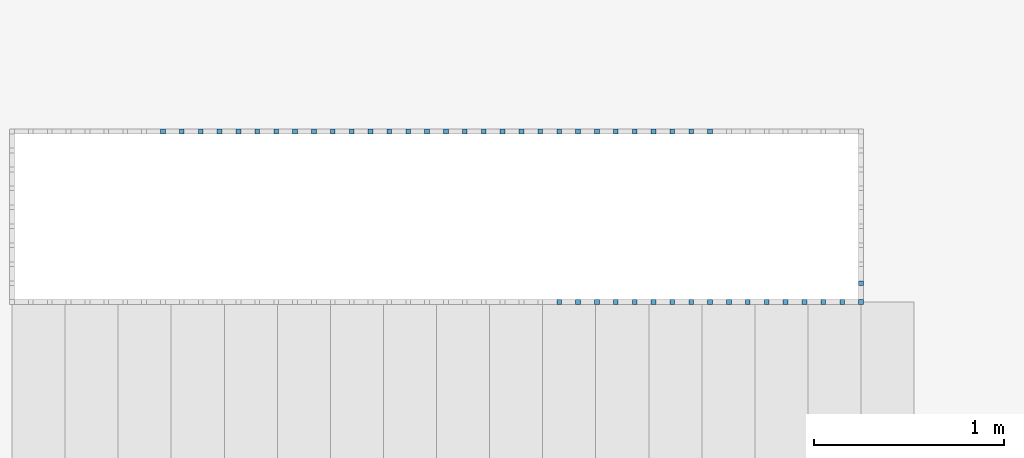
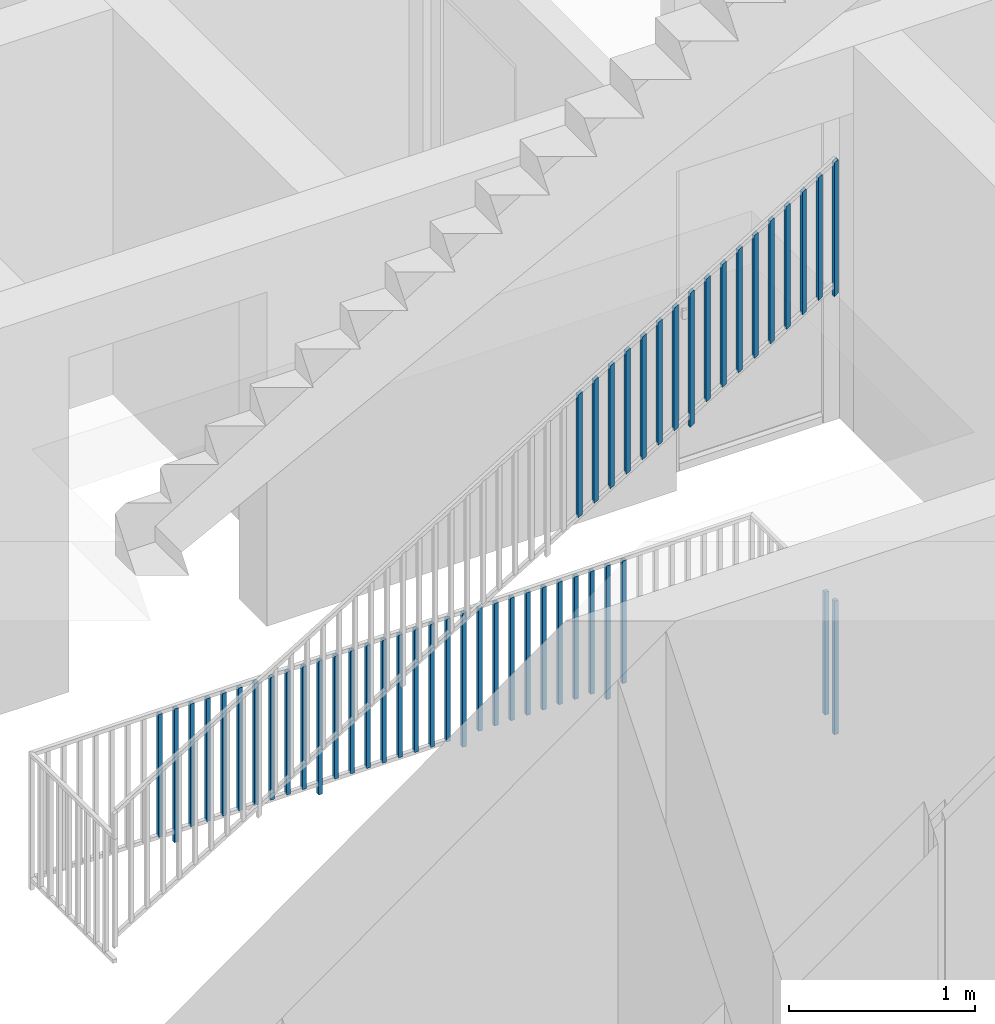
# One storey, part 34 of 48: 49 building element parts, 2 elements without a shape of their own.
"""IFC4 building model written with IfcOpenShell, lengths in metres."""

from ifc_helpers import new_model, entity, si_unit, converted_unit, derived_unit, direction, frame, origin_with_axes, place, context, subcontext, project, spatial, polygons, material, type_object, element, aggregate, save


model = new_model("IFC4")

# Units and contexts
model_context = context("Model", 3, precision=1e-05, world=origin_with_axes(), true_north=direction((0.0, 1.0)))
body_context = subcontext(model_context, "Body", "Model", "MODEL_VIEW")
ifc_project = project(units=[si_unit("LENGTHUNIT", "METRE"), si_unit("AREAUNIT", "SQUARE_METRE"), si_unit("VOLUMEUNIT", "CUBIC_METRE"), converted_unit("PLANEANGLEUNIT", "DEGREE", entity("IfcPlaneAngleMeasure", 0.0174532925199), si_unit("PLANEANGLEUNIT", "RADIAN"), dimensions=[0, 0, 0, 0, 0, 0, 0]), converted_unit("TIMEUNIT", "Year", entity("IfcTimeMeasure", 31556926.0), si_unit("TIMEUNIT", "SECOND"), dimensions=[0, 0, 1, 0, 0, 0, 0]), si_unit("MASSUNIT", "GRAM", prefix="KILO"), si_unit("THERMODYNAMICTEMPERATUREUNIT", "DEGREE_CELSIUS"), si_unit("LUMINOUSINTENSITYUNIT", "LUMEN"), si_unit("ENERGYUNIT", "JOULE", prefix="MEGA"), derived_unit("THERMALCONDUCTANCEUNIT", [(si_unit("POWERUNIT", "WATT"), 1), (si_unit("LENGTHUNIT", "METRE"), -1), (si_unit("THERMODYNAMICTEMPERATUREUNIT", "KELVIN"), -1)]), derived_unit("SPECIFICHEATCAPACITYUNIT", [(si_unit("ENERGYUNIT", "JOULE"), 1), (si_unit("MASSUNIT", "GRAM", prefix="KILO"), -1), (si_unit("THERMODYNAMICTEMPERATUREUNIT", "KELVIN"), -1)]), derived_unit("MASSDENSITYUNIT", [(si_unit("MASSUNIT", "GRAM", prefix="KILO"), 1), (si_unit("VOLUMEUNIT", "CUBIC_METRE"), -1)])], contexts=[model_context])

# Site, building, storey, space
site_placement = place(None, origin_with_axes())
site = spatial("IfcSite", under=ifc_project, at=site_placement, CompositionType="ELEMENT")
building_placement = place(site_placement, origin_with_axes())
building = spatial("IfcBuilding", under=site, at=building_placement, CompositionType="ELEMENT")
storey_placement = place(building_placement, frame((0.0, 0.0, 3.4), z_axis=(0.0, 0.0, 1.0), x_axis=(1.0, 0.0, 0.0)))
storey = spatial("IfcBuildingStorey", under=building, at=storey_placement, Name="1. Geschoss", CompositionType="ELEMENT", Elevation=3.4)
space_placement = place(storey_placement, frame((-3.4421993804, -2.52881223104, 0.0), z_axis=(0.0, 0.0, 1.0), x_axis=(1.0, 0.0, 0.0)))
space = spatial("IfcSpace", under=storey, at=space_placement, CompositionType="ELEMENT", PredefinedType="INTERNAL")

# Railing, building element parts
railing_type = type_object("IfcRailingType", PredefinedType="NOTDEFINED")
railing_1_placement = place(space_placement, frame((0.0, 1.5, 0.17), z_axis=(0.0, 0.0, 1.0), x_axis=(1.0, 0.0, 0.0)))
railing_1 = element("IfcRailing", 1, at=railing_1_placement, inside=space, type_object=railing_type, PredefinedType="NOTDEFINED")
ifc_material = material()
building_element_part_1_placement = place(railing_1_placement, origin_with_axes())
building_element_part_1 = element("IfcBuildingElementPart", 2, at=building_element_part_1_placement, material=ifc_material, PredefinedType="NOTDEFINED", context=body_context, shape_type="Tessellation", body=[
    polygons([(4.4925, -0.0125, 2.72758928571), (4.4925, 0.0125, 2.72758928571), (4.4925, 0.0125, 3.60758928571), (4.4925, -0.0125, 3.60758928571), (4.4675, -0.0125, 2.71241071429), (4.4675, 0.0125, 2.71241071429), (4.4675, 0.0125, 3.59241071429), (4.4675, -0.0125, 3.59241071429)], [[[1, 2, 3, 4]], [[1, 5, 6, 2]], [[2, 6, 7, 3]], [[4, 3, 7, 8]], [[5, 1, 4, 8]], [[6, 5, 8, 7]]], closed=True),
])
building_element_part_2_placement = place(railing_1_placement, origin_with_axes())
building_element_part_2 = element("IfcBuildingElementPart", 3, at=building_element_part_2_placement, material=ifc_material, PredefinedType="NOTDEFINED", context=body_context, shape_type="Tessellation", body=[
    polygons([(2.89961111111, -0.0125, 1.8304781746), (2.89961111111, 0.0125, 1.8304781746), (2.89961111111, 0.0125, 2.6379781746), (2.89961111111, -0.0125, 2.6379781746), (2.87461111111, -0.0125, 1.81529960317), (2.87461111111, 0.0125, 1.81529960317), (2.87461111111, 0.0125, 2.62279960317), (2.87461111111, -0.0125, 2.62279960317)], [[[1, 2, 3, 4]], [[1, 5, 6, 2]], [[2, 6, 7, 3]], [[4, 3, 7, 8]], [[5, 1, 4, 8]], [[6, 5, 8, 7]]], closed=True),
])
building_element_part_3_placement = place(railing_1_placement, origin_with_axes())
building_element_part_3 = element("IfcBuildingElementPart", 4, at=building_element_part_3_placement, material=ifc_material, PredefinedType="NOTDEFINED", context=body_context, shape_type="Tessellation", body=[
    polygons([(2.99916666667, -0.0125, 1.89092261905), (2.99916666667, 0.0125, 1.89092261905), (2.99916666667, 0.0125, 2.69842261905), (2.99916666667, -0.0125, 2.69842261905), (2.97416666667, -0.0125, 1.87574404762), (2.97416666667, 0.0125, 1.87574404762), (2.97416666667, 0.0125, 2.68324404762), (2.97416666667, -0.0125, 2.68324404762)], [[[1, 2, 3, 4]], [[1, 5, 6, 2]], [[2, 6, 7, 3]], [[4, 3, 7, 8]], [[5, 1, 4, 8]], [[6, 5, 8, 7]]], closed=True),
])
building_element_part_4_placement = place(railing_1_placement, origin_with_axes())
building_element_part_4 = element("IfcBuildingElementPart", 5, at=building_element_part_4_placement, material=ifc_material, PredefinedType="NOTDEFINED", context=body_context, shape_type="Tessellation", body=[
    polygons([(3.09872222222, -0.0125, 1.95136706349), (3.09872222222, 0.0125, 1.95136706349), (3.09872222222, 0.0125, 2.75886706349), (3.09872222222, -0.0125, 2.75886706349), (3.07372222222, -0.0125, 1.93618849206), (3.07372222222, 0.0125, 1.93618849206), (3.07372222222, 0.0125, 2.74368849206), (3.07372222222, -0.0125, 2.74368849206)], [[[1, 2, 3, 4]], [[1, 5, 6, 2]], [[2, 6, 7, 3]], [[4, 3, 7, 8]], [[5, 1, 4, 8]], [[6, 5, 8, 7]]], closed=True),
])
building_element_part_5_placement = place(railing_1_placement, origin_with_axes())
building_element_part_5 = element("IfcBuildingElementPart", 6, at=building_element_part_5_placement, material=ifc_material, PredefinedType="NOTDEFINED", context=body_context, shape_type="Tessellation", body=[
    polygons([(3.19827777778, -0.0125, 2.01181150794), (3.19827777778, 0.0125, 2.01181150794), (3.19827777778, 0.0125, 2.81931150794), (3.19827777778, -0.0125, 2.81931150794), (3.17327777778, -0.0125, 1.99663293651), (3.17327777778, 0.0125, 1.99663293651), (3.17327777778, 0.0125, 2.80413293651), (3.17327777778, -0.0125, 2.80413293651)], [[[1, 2, 3, 4]], [[1, 5, 6, 2]], [[2, 6, 7, 3]], [[4, 3, 7, 8]], [[5, 1, 4, 8]], [[6, 5, 8, 7]]], closed=True),
])
building_element_part_6_placement = place(railing_1_placement, origin_with_axes())
building_element_part_6 = element("IfcBuildingElementPart", 7, at=building_element_part_6_placement, material=ifc_material, PredefinedType="NOTDEFINED", context=body_context, shape_type="Tessellation", body=[
    polygons([(3.29783333333, -0.0125, 2.07225595238), (3.29783333333, 0.0125, 2.07225595238), (3.29783333333, 0.0125, 2.87975595238), (3.29783333333, -0.0125, 2.87975595238), (3.27283333333, -0.0125, 2.05707738095), (3.27283333333, 0.0125, 2.05707738095), (3.27283333333, 0.0125, 2.86457738095), (3.27283333333, -0.0125, 2.86457738095)], [[[1, 2, 3, 4]], [[1, 5, 6, 2]], [[2, 6, 7, 3]], [[4, 3, 7, 8]], [[5, 1, 4, 8]], [[6, 5, 8, 7]]], closed=True),
])
building_element_part_7_placement = place(railing_1_placement, origin_with_axes())
building_element_part_7 = element("IfcBuildingElementPart", 8, at=building_element_part_7_placement, material=ifc_material, PredefinedType="NOTDEFINED", context=body_context, shape_type="Tessellation", body=[
    polygons([(3.39738888889, -0.0125, 2.13270039683), (3.39738888889, 0.0125, 2.13270039683), (3.39738888889, 0.0125, 2.94020039683), (3.39738888889, -0.0125, 2.94020039683), (3.37238888889, -0.0125, 2.1175218254), (3.37238888889, 0.0125, 2.1175218254), (3.37238888889, 0.0125, 2.9250218254), (3.37238888889, -0.0125, 2.9250218254)], [[[1, 2, 3, 4]], [[1, 5, 6, 2]], [[2, 6, 7, 3]], [[4, 3, 7, 8]], [[5, 1, 4, 8]], [[6, 5, 8, 7]]], closed=True),
])
building_element_part_8_placement = place(railing_1_placement, origin_with_axes())
building_element_part_8 = element("IfcBuildingElementPart", 9, at=building_element_part_8_placement, material=ifc_material, PredefinedType="NOTDEFINED", context=body_context, shape_type="Tessellation", body=[
    polygons([(3.49694444444, -0.0125, 2.19314484127), (3.49694444444, 0.0125, 2.19314484127), (3.49694444444, 0.0125, 3.00064484127), (3.49694444444, -0.0125, 3.00064484127), (3.47194444444, -0.0125, 2.17796626984), (3.47194444444, 0.0125, 2.17796626984), (3.47194444444, 0.0125, 2.98546626984), (3.47194444444, -0.0125, 2.98546626984)], [[[1, 2, 3, 4]], [[1, 5, 6, 2]], [[2, 6, 7, 3]], [[4, 3, 7, 8]], [[5, 1, 4, 8]], [[6, 5, 8, 7]]], closed=True),
])
building_element_part_9_placement = place(railing_1_placement, origin_with_axes())
building_element_part_9 = element("IfcBuildingElementPart", 10, at=building_element_part_9_placement, material=ifc_material, PredefinedType="NOTDEFINED", context=body_context, shape_type="Tessellation", body=[
    polygons([(3.5965, -0.0125, 2.18358928571), (3.5965, 0.0125, 2.18358928571), (3.5965, 0.0125, 3.06358928571), (3.5965, -0.0125, 3.06358928571), (3.5715, -0.0125, 2.16841071429), (3.5715, 0.0125, 2.16841071429), (3.5715, 0.0125, 3.04841071429), (3.5715, -0.0125, 3.04841071429)], [[[1, 2, 3, 4]], [[1, 5, 6, 2]], [[2, 6, 7, 3]], [[4, 3, 7, 8]], [[5, 1, 4, 8]], [[6, 5, 8, 7]]], closed=True),
])
building_element_part_10_placement = place(railing_1_placement, origin_with_axes())
building_element_part_10 = element("IfcBuildingElementPart", 11, at=building_element_part_10_placement, material=ifc_material, PredefinedType="NOTDEFINED", context=body_context, shape_type="Tessellation", body=[
    polygons([(3.69605555556, -0.0125, 2.31403373016), (3.69605555556, 0.0125, 2.31403373016), (3.69605555556, 0.0125, 3.12153373016), (3.69605555556, -0.0125, 3.12153373016), (3.67105555556, -0.0125, 2.29885515873), (3.67105555556, 0.0125, 2.29885515873), (3.67105555556, 0.0125, 3.10635515873), (3.67105555556, -0.0125, 3.10635515873)], [[[1, 2, 3, 4]], [[1, 5, 6, 2]], [[2, 6, 7, 3]], [[4, 3, 7, 8]], [[5, 1, 4, 8]], [[6, 5, 8, 7]]], closed=True),
])
building_element_part_11_placement = place(railing_1_placement, origin_with_axes())
building_element_part_11 = element("IfcBuildingElementPart", 12, at=building_element_part_11_placement, material=ifc_material, PredefinedType="NOTDEFINED", context=body_context, shape_type="Tessellation", body=[
    polygons([(3.79561111111, -0.0125, 2.3744781746), (3.79561111111, 0.0125, 2.3744781746), (3.79561111111, 0.0125, 3.1819781746), (3.79561111111, -0.0125, 3.1819781746), (3.77061111111, -0.0125, 2.35929960317), (3.77061111111, 0.0125, 2.35929960317), (3.77061111111, 0.0125, 3.16679960317), (3.77061111111, -0.0125, 3.16679960317)], [[[1, 2, 3, 4]], [[1, 5, 6, 2]], [[2, 6, 7, 3]], [[4, 3, 7, 8]], [[5, 1, 4, 8]], [[6, 5, 8, 7]]], closed=True),
])
building_element_part_12_placement = place(railing_1_placement, origin_with_axes())
building_element_part_12 = element("IfcBuildingElementPart", 13, at=building_element_part_12_placement, material=ifc_material, PredefinedType="NOTDEFINED", context=body_context, shape_type="Tessellation", body=[
    polygons([(3.89516666667, -0.0125, 2.43492261905), (3.89516666667, 0.0125, 2.43492261905), (3.89516666667, 0.0125, 3.24242261905), (3.89516666667, -0.0125, 3.24242261905), (3.87016666667, -0.0125, 2.41974404762), (3.87016666667, 0.0125, 2.41974404762), (3.87016666667, 0.0125, 3.22724404762), (3.87016666667, -0.0125, 3.22724404762)], [[[1, 2, 3, 4]], [[1, 5, 6, 2]], [[2, 6, 7, 3]], [[4, 3, 7, 8]], [[5, 1, 4, 8]], [[6, 5, 8, 7]]], closed=True),
])
building_element_part_13_placement = place(railing_1_placement, origin_with_axes())
building_element_part_13 = element("IfcBuildingElementPart", 14, at=building_element_part_13_placement, material=ifc_material, PredefinedType="NOTDEFINED", context=body_context, shape_type="Tessellation", body=[
    polygons([(3.99472222222, -0.0125, 2.49536706349), (3.99472222222, 0.0125, 2.49536706349), (3.99472222222, 0.0125, 3.30286706349), (3.99472222222, -0.0125, 3.30286706349), (3.96972222222, -0.0125, 2.48018849206), (3.96972222222, 0.0125, 2.48018849206), (3.96972222222, 0.0125, 3.28768849206), (3.96972222222, -0.0125, 3.28768849206)], [[[1, 2, 3, 4]], [[1, 5, 6, 2]], [[2, 6, 7, 3]], [[4, 3, 7, 8]], [[5, 1, 4, 8]], [[6, 5, 8, 7]]], closed=True),
])
building_element_part_14_placement = place(railing_1_placement, origin_with_axes())
building_element_part_14 = element("IfcBuildingElementPart", 15, at=building_element_part_14_placement, material=ifc_material, PredefinedType="NOTDEFINED", context=body_context, shape_type="Tessellation", body=[
    polygons([(4.09427777778, -0.0125, 2.55581150794), (4.09427777778, 0.0125, 2.55581150794), (4.09427777778, 0.0125, 3.36331150794), (4.09427777778, -0.0125, 3.36331150794), (4.06927777778, -0.0125, 2.54063293651), (4.06927777778, 0.0125, 2.54063293651), (4.06927777778, 0.0125, 3.34813293651), (4.06927777778, -0.0125, 3.34813293651)], [[[1, 2, 3, 4]], [[1, 5, 6, 2]], [[2, 6, 7, 3]], [[4, 3, 7, 8]], [[5, 1, 4, 8]], [[6, 5, 8, 7]]], closed=True),
])
building_element_part_15_placement = place(railing_1_placement, origin_with_axes())
building_element_part_15 = element("IfcBuildingElementPart", 16, at=building_element_part_15_placement, material=ifc_material, PredefinedType="NOTDEFINED", context=body_context, shape_type="Tessellation", body=[
    polygons([(4.19383333333, -0.0125, 2.61625595238), (4.19383333333, 0.0125, 2.61625595238), (4.19383333333, 0.0125, 3.42375595238), (4.19383333333, -0.0125, 3.42375595238), (4.16883333333, -0.0125, 2.60107738095), (4.16883333333, 0.0125, 2.60107738095), (4.16883333333, 0.0125, 3.40857738095), (4.16883333333, -0.0125, 3.40857738095)], [[[1, 2, 3, 4]], [[1, 5, 6, 2]], [[2, 6, 7, 3]], [[4, 3, 7, 8]], [[5, 1, 4, 8]], [[6, 5, 8, 7]]], closed=True),
])
building_element_part_16_placement = place(railing_1_placement, origin_with_axes())
building_element_part_16 = element("IfcBuildingElementPart", 17, at=building_element_part_16_placement, material=ifc_material, PredefinedType="NOTDEFINED", context=body_context, shape_type="Tessellation", body=[
    polygons([(4.29338888889, -0.0125, 2.67670039683), (4.29338888889, 0.0125, 2.67670039683), (4.29338888889, 0.0125, 3.48420039683), (4.29338888889, -0.0125, 3.48420039683), (4.26838888889, -0.0125, 2.6615218254), (4.26838888889, 0.0125, 2.6615218254), (4.26838888889, 0.0125, 3.4690218254), (4.26838888889, -0.0125, 3.4690218254)], [[[1, 2, 3, 4]], [[1, 5, 6, 2]], [[2, 6, 7, 3]], [[4, 3, 7, 8]], [[5, 1, 4, 8]], [[6, 5, 8, 7]]], closed=True),
])
building_element_part_17_placement = place(railing_1_placement, origin_with_axes())
building_element_part_17 = element("IfcBuildingElementPart", 18, at=building_element_part_17_placement, material=ifc_material, PredefinedType="NOTDEFINED", context=body_context, shape_type="Tessellation", body=[
    polygons([(4.39294444444, -0.0125, 2.73714484127), (4.39294444444, 0.0125, 2.73714484127), (4.39294444444, 0.0125, 3.54464484127), (4.39294444444, -0.0125, 3.54464484127), (4.36794444444, -0.0125, 2.72196626984), (4.36794444444, 0.0125, 2.72196626984), (4.36794444444, 0.0125, 3.52946626984), (4.36794444444, -0.0125, 3.52946626984)], [[[1, 2, 3, 4]], [[1, 5, 6, 2]], [[2, 6, 7, 3]], [[4, 3, 7, 8]], [[5, 1, 4, 8]], [[6, 5, 8, 7]]], closed=True),
])
aggregate(railing_1, [building_element_part_1, building_element_part_2, building_element_part_3, building_element_part_4, building_element_part_5, building_element_part_6, building_element_part_7, building_element_part_8, building_element_part_9, building_element_part_10, building_element_part_11, building_element_part_12, building_element_part_13, building_element_part_14, building_element_part_15, building_element_part_16, building_element_part_17])

railing_2_placement = place(space_placement, frame((0.0, 1.5, 0.0), z_axis=(0.0, 0.0, 1.0), x_axis=(1.0, 0.0, 0.0)))
railing_2 = element("IfcRailing", 19, at=railing_2_placement, inside=space, type_object=railing_type, PredefinedType="NOTDEFINED")
building_element_part_18_placement = place(railing_2_placement, origin_with_axes())
building_element_part_18 = element("IfcBuildingElementPart", 20, at=building_element_part_18_placement, material=ifc_material, PredefinedType="NOTDEFINED", context=body_context, shape_type="Tessellation", body=[
    polygons([(4.4675, -0.0125, 0.0), (4.4925, -0.0125, 0.0), (4.4925, -0.0125, 0.88), (4.4675, -0.0125, 0.88), (4.4675, 0.0125, 0.0), (4.4925, 0.0125, 0.0), (4.4925, 0.0125, 0.88), (4.4675, 0.0125, 0.88)], [[[1, 2, 3, 4]], [[1, 5, 6, 2]], [[2, 6, 7, 3]], [[4, 3, 7, 8]], [[5, 1, 4, 8]], [[6, 5, 8, 7]]], closed=True),
])
building_element_part_19_placement = place(railing_2_placement, origin_with_axes())
building_element_part_19 = element("IfcBuildingElementPart", 21, at=building_element_part_19_placement, material=ifc_material, PredefinedType="NOTDEFINED", context=body_context, shape_type="Tessellation", body=[
    polygons([(0.808944444444, 0.8875, 0.07), (0.808944444444, 0.9125, 0.07), (0.808944444444, 0.9125, 0.8775), (0.808944444444, 0.8875, 0.8775), (0.783944444444, 0.8875, 0.07), (0.783944444444, 0.9125, 0.07), (0.783944444444, 0.9125, 0.8775), (0.783944444444, 0.8875, 0.8775)], [[[1, 2, 3, 4]], [[1, 5, 6, 2]], [[2, 6, 7, 3]], [[4, 3, 7, 8]], [[5, 1, 4, 8]], [[6, 5, 8, 7]]], closed=True),
])
building_element_part_20_placement = place(railing_2_placement, origin_with_axes())
building_element_part_20 = element("IfcBuildingElementPart", 22, at=building_element_part_20_placement, material=ifc_material, PredefinedType="NOTDEFINED", context=body_context, shape_type="Tessellation", body=[
    polygons([(0.9085, 0.8875, 0.0), (0.9085, 0.9125, 0.0), (0.9085, 0.9125, 0.88), (0.9085, 0.8875, 0.88), (0.8835, 0.8875, 0.0), (0.8835, 0.9125, 0.0), (0.8835, 0.9125, 0.88), (0.8835, 0.8875, 0.88)], [[[1, 2, 3, 4]], [[1, 5, 6, 2]], [[2, 6, 7, 3]], [[4, 3, 7, 8]], [[5, 1, 4, 8]], [[6, 5, 8, 7]]], closed=True),
])
building_element_part_21_placement = place(railing_2_placement, origin_with_axes())
building_element_part_21 = element("IfcBuildingElementPart", 23, at=building_element_part_21_placement, material=ifc_material, PredefinedType="NOTDEFINED", context=body_context, shape_type="Tessellation", body=[
    polygons([(1.00805555556, 0.8875, 0.07), (1.00805555556, 0.9125, 0.07), (1.00805555556, 0.9125, 0.8775), (1.00805555556, 0.8875, 0.8775), (0.983055555556, 0.8875, 0.07), (0.983055555556, 0.9125, 0.07), (0.983055555556, 0.9125, 0.8775), (0.983055555556, 0.8875, 0.8775)], [[[1, 2, 3, 4]], [[1, 5, 6, 2]], [[2, 6, 7, 3]], [[4, 3, 7, 8]], [[5, 1, 4, 8]], [[6, 5, 8, 7]]], closed=True),
])
building_element_part_22_placement = place(railing_2_placement, origin_with_axes())
building_element_part_22 = element("IfcBuildingElementPart", 24, at=building_element_part_22_placement, material=ifc_material, PredefinedType="NOTDEFINED", context=body_context, shape_type="Tessellation", body=[
    polygons([(1.10761111111, 0.8875, 0.07), (1.10761111111, 0.9125, 0.07), (1.10761111111, 0.9125, 0.8775), (1.10761111111, 0.8875, 0.8775), (1.08261111111, 0.8875, 0.07), (1.08261111111, 0.9125, 0.07), (1.08261111111, 0.9125, 0.8775), (1.08261111111, 0.8875, 0.8775)], [[[1, 2, 3, 4]], [[1, 5, 6, 2]], [[2, 6, 7, 3]], [[4, 3, 7, 8]], [[5, 1, 4, 8]], [[6, 5, 8, 7]]], closed=True),
])
building_element_part_23_placement = place(railing_2_placement, origin_with_axes())
building_element_part_23 = element("IfcBuildingElementPart", 25, at=building_element_part_23_placement, material=ifc_material, PredefinedType="NOTDEFINED", context=body_context, shape_type="Tessellation", body=[
    polygons([(1.20716666667, 0.8875, 0.07), (1.20716666667, 0.9125, 0.07), (1.20716666667, 0.9125, 0.8775), (1.20716666667, 0.8875, 0.8775), (1.18216666667, 0.8875, 0.07), (1.18216666667, 0.9125, 0.07), (1.18216666667, 0.9125, 0.8775), (1.18216666667, 0.8875, 0.8775)], [[[1, 2, 3, 4]], [[1, 5, 6, 2]], [[2, 6, 7, 3]], [[4, 3, 7, 8]], [[5, 1, 4, 8]], [[6, 5, 8, 7]]], closed=True),
])
building_element_part_24_placement = place(railing_2_placement, origin_with_axes())
building_element_part_24 = element("IfcBuildingElementPart", 26, at=building_element_part_24_placement, material=ifc_material, PredefinedType="NOTDEFINED", context=body_context, shape_type="Tessellation", body=[
    polygons([(1.30672222222, 0.8875, 0.07), (1.30672222222, 0.9125, 0.07), (1.30672222222, 0.9125, 0.8775), (1.30672222222, 0.8875, 0.8775), (1.28172222222, 0.8875, 0.07), (1.28172222222, 0.9125, 0.07), (1.28172222222, 0.9125, 0.8775), (1.28172222222, 0.8875, 0.8775)], [[[1, 2, 3, 4]], [[1, 5, 6, 2]], [[2, 6, 7, 3]], [[4, 3, 7, 8]], [[5, 1, 4, 8]], [[6, 5, 8, 7]]], closed=True),
])
building_element_part_25_placement = place(railing_2_placement, origin_with_axes())
building_element_part_25 = element("IfcBuildingElementPart", 27, at=building_element_part_25_placement, material=ifc_material, PredefinedType="NOTDEFINED", context=body_context, shape_type="Tessellation", body=[
    polygons([(1.40627777778, 0.8875, 0.07), (1.40627777778, 0.9125, 0.07), (1.40627777778, 0.9125, 0.8775), (1.40627777778, 0.8875, 0.8775), (1.38127777778, 0.8875, 0.07), (1.38127777778, 0.9125, 0.07), (1.38127777778, 0.9125, 0.8775), (1.38127777778, 0.8875, 0.8775)], [[[1, 2, 3, 4]], [[1, 5, 6, 2]], [[2, 6, 7, 3]], [[4, 3, 7, 8]], [[5, 1, 4, 8]], [[6, 5, 8, 7]]], closed=True),
])
building_element_part_26_placement = place(railing_2_placement, origin_with_axes())
building_element_part_26 = element("IfcBuildingElementPart", 28, at=building_element_part_26_placement, material=ifc_material, PredefinedType="NOTDEFINED", context=body_context, shape_type="Tessellation", body=[
    polygons([(1.50583333333, 0.8875, 0.07), (1.50583333333, 0.9125, 0.07), (1.50583333333, 0.9125, 0.8775), (1.50583333333, 0.8875, 0.8775), (1.48083333333, 0.8875, 0.07), (1.48083333333, 0.9125, 0.07), (1.48083333333, 0.9125, 0.8775), (1.48083333333, 0.8875, 0.8775)], [[[1, 2, 3, 4]], [[1, 5, 6, 2]], [[2, 6, 7, 3]], [[4, 3, 7, 8]], [[5, 1, 4, 8]], [[6, 5, 8, 7]]], closed=True),
])
building_element_part_27_placement = place(railing_2_placement, origin_with_axes())
building_element_part_27 = element("IfcBuildingElementPart", 29, at=building_element_part_27_placement, material=ifc_material, PredefinedType="NOTDEFINED", context=body_context, shape_type="Tessellation", body=[
    polygons([(1.60538888889, 0.8875, 0.07), (1.60538888889, 0.9125, 0.07), (1.60538888889, 0.9125, 0.8775), (1.60538888889, 0.8875, 0.8775), (1.58038888889, 0.8875, 0.07), (1.58038888889, 0.9125, 0.07), (1.58038888889, 0.9125, 0.8775), (1.58038888889, 0.8875, 0.8775)], [[[1, 2, 3, 4]], [[1, 5, 6, 2]], [[2, 6, 7, 3]], [[4, 3, 7, 8]], [[5, 1, 4, 8]], [[6, 5, 8, 7]]], closed=True),
])
building_element_part_28_placement = place(railing_2_placement, origin_with_axes())
building_element_part_28 = element("IfcBuildingElementPart", 30, at=building_element_part_28_placement, material=ifc_material, PredefinedType="NOTDEFINED", context=body_context, shape_type="Tessellation", body=[
    polygons([(1.70494444444, 0.8875, 0.07), (1.70494444444, 0.9125, 0.07), (1.70494444444, 0.9125, 0.8775), (1.70494444444, 0.8875, 0.8775), (1.67994444444, 0.8875, 0.07), (1.67994444444, 0.9125, 0.07), (1.67994444444, 0.9125, 0.8775), (1.67994444444, 0.8875, 0.8775)], [[[1, 2, 3, 4]], [[1, 5, 6, 2]], [[2, 6, 7, 3]], [[4, 3, 7, 8]], [[5, 1, 4, 8]], [[6, 5, 8, 7]]], closed=True),
])
building_element_part_29_placement = place(railing_2_placement, origin_with_axes())
building_element_part_29 = element("IfcBuildingElementPart", 31, at=building_element_part_29_placement, material=ifc_material, PredefinedType="NOTDEFINED", context=body_context, shape_type="Tessellation", body=[
    polygons([(1.8045, 0.8875, 0.0), (1.8045, 0.9125, 0.0), (1.8045, 0.9125, 0.88), (1.8045, 0.8875, 0.88), (1.7795, 0.8875, 0.0), (1.7795, 0.9125, 0.0), (1.7795, 0.9125, 0.88), (1.7795, 0.8875, 0.88)], [[[1, 2, 3, 4]], [[1, 5, 6, 2]], [[2, 6, 7, 3]], [[4, 3, 7, 8]], [[5, 1, 4, 8]], [[6, 5, 8, 7]]], closed=True),
])
building_element_part_30_placement = place(railing_2_placement, origin_with_axes())
building_element_part_30 = element("IfcBuildingElementPart", 32, at=building_element_part_30_placement, material=ifc_material, PredefinedType="NOTDEFINED", context=body_context, shape_type="Tessellation", body=[
    polygons([(1.90405555556, 0.8875, 0.07), (1.90405555556, 0.9125, 0.07), (1.90405555556, 0.9125, 0.8775), (1.90405555556, 0.8875, 0.8775), (1.87905555556, 0.8875, 0.07), (1.87905555556, 0.9125, 0.07), (1.87905555556, 0.9125, 0.8775), (1.87905555556, 0.8875, 0.8775)], [[[1, 2, 3, 4]], [[1, 5, 6, 2]], [[2, 6, 7, 3]], [[4, 3, 7, 8]], [[5, 1, 4, 8]], [[6, 5, 8, 7]]], closed=True),
])
building_element_part_31_placement = place(railing_2_placement, origin_with_axes())
building_element_part_31 = element("IfcBuildingElementPart", 33, at=building_element_part_31_placement, material=ifc_material, PredefinedType="NOTDEFINED", context=body_context, shape_type="Tessellation", body=[
    polygons([(2.00361111111, 0.8875, 0.07), (2.00361111111, 0.9125, 0.07), (2.00361111111, 0.9125, 0.8775), (2.00361111111, 0.8875, 0.8775), (1.97861111111, 0.8875, 0.07), (1.97861111111, 0.9125, 0.07), (1.97861111111, 0.9125, 0.8775), (1.97861111111, 0.8875, 0.8775)], [[[1, 2, 3, 4]], [[1, 5, 6, 2]], [[2, 6, 7, 3]], [[4, 3, 7, 8]], [[5, 1, 4, 8]], [[6, 5, 8, 7]]], closed=True),
])
building_element_part_32_placement = place(railing_2_placement, origin_with_axes())
building_element_part_32 = element("IfcBuildingElementPart", 34, at=building_element_part_32_placement, material=ifc_material, PredefinedType="NOTDEFINED", context=body_context, shape_type="Tessellation", body=[
    polygons([(2.10316666667, 0.8875, 0.07), (2.10316666667, 0.9125, 0.07), (2.10316666667, 0.9125, 0.8775), (2.10316666667, 0.8875, 0.8775), (2.07816666667, 0.8875, 0.07), (2.07816666667, 0.9125, 0.07), (2.07816666667, 0.9125, 0.8775), (2.07816666667, 0.8875, 0.8775)], [[[1, 2, 3, 4]], [[1, 5, 6, 2]], [[2, 6, 7, 3]], [[4, 3, 7, 8]], [[5, 1, 4, 8]], [[6, 5, 8, 7]]], closed=True),
])
building_element_part_33_placement = place(railing_2_placement, origin_with_axes())
building_element_part_33 = element("IfcBuildingElementPart", 35, at=building_element_part_33_placement, material=ifc_material, PredefinedType="NOTDEFINED", context=body_context, shape_type="Tessellation", body=[
    polygons([(2.20272222222, 0.8875, 0.07), (2.20272222222, 0.9125, 0.07), (2.20272222222, 0.9125, 0.8775), (2.20272222222, 0.8875, 0.8775), (2.17772222222, 0.8875, 0.07), (2.17772222222, 0.9125, 0.07), (2.17772222222, 0.9125, 0.8775), (2.17772222222, 0.8875, 0.8775)], [[[1, 2, 3, 4]], [[1, 5, 6, 2]], [[2, 6, 7, 3]], [[4, 3, 7, 8]], [[5, 1, 4, 8]], [[6, 5, 8, 7]]], closed=True),
])
building_element_part_34_placement = place(railing_2_placement, origin_with_axes())
building_element_part_34 = element("IfcBuildingElementPart", 36, at=building_element_part_34_placement, material=ifc_material, PredefinedType="NOTDEFINED", context=body_context, shape_type="Tessellation", body=[
    polygons([(2.30227777778, 0.8875, 0.07), (2.30227777778, 0.9125, 0.07), (2.30227777778, 0.9125, 0.8775), (2.30227777778, 0.8875, 0.8775), (2.27727777778, 0.8875, 0.07), (2.27727777778, 0.9125, 0.07), (2.27727777778, 0.9125, 0.8775), (2.27727777778, 0.8875, 0.8775)], [[[1, 2, 3, 4]], [[1, 5, 6, 2]], [[2, 6, 7, 3]], [[4, 3, 7, 8]], [[5, 1, 4, 8]], [[6, 5, 8, 7]]], closed=True),
])
building_element_part_35_placement = place(railing_2_placement, origin_with_axes())
building_element_part_35 = element("IfcBuildingElementPart", 37, at=building_element_part_35_placement, material=ifc_material, PredefinedType="NOTDEFINED", context=body_context, shape_type="Tessellation", body=[
    polygons([(2.40183333333, 0.8875, 0.07), (2.40183333333, 0.9125, 0.07), (2.40183333333, 0.9125, 0.8775), (2.40183333333, 0.8875, 0.8775), (2.37683333333, 0.8875, 0.07), (2.37683333333, 0.9125, 0.07), (2.37683333333, 0.9125, 0.8775), (2.37683333333, 0.8875, 0.8775)], [[[1, 2, 3, 4]], [[1, 5, 6, 2]], [[2, 6, 7, 3]], [[4, 3, 7, 8]], [[5, 1, 4, 8]], [[6, 5, 8, 7]]], closed=True),
])
building_element_part_36_placement = place(railing_2_placement, origin_with_axes())
building_element_part_36 = element("IfcBuildingElementPart", 38, at=building_element_part_36_placement, material=ifc_material, PredefinedType="NOTDEFINED", context=body_context, shape_type="Tessellation", body=[
    polygons([(2.50138888889, 0.8875, 0.07), (2.50138888889, 0.9125, 0.07), (2.50138888889, 0.9125, 0.8775), (2.50138888889, 0.8875, 0.8775), (2.47638888889, 0.8875, 0.07), (2.47638888889, 0.9125, 0.07), (2.47638888889, 0.9125, 0.8775), (2.47638888889, 0.8875, 0.8775)], [[[1, 2, 3, 4]], [[1, 5, 6, 2]], [[2, 6, 7, 3]], [[4, 3, 7, 8]], [[5, 1, 4, 8]], [[6, 5, 8, 7]]], closed=True),
])
building_element_part_37_placement = place(railing_2_placement, origin_with_axes())
building_element_part_37 = element("IfcBuildingElementPart", 39, at=building_element_part_37_placement, material=ifc_material, PredefinedType="NOTDEFINED", context=body_context, shape_type="Tessellation", body=[
    polygons([(2.60094444444, 0.8875, 0.07), (2.60094444444, 0.9125, 0.07), (2.60094444444, 0.9125, 0.8775), (2.60094444444, 0.8875, 0.8775), (2.57594444444, 0.8875, 0.07), (2.57594444444, 0.9125, 0.07), (2.57594444444, 0.9125, 0.8775), (2.57594444444, 0.8875, 0.8775)], [[[1, 2, 3, 4]], [[1, 5, 6, 2]], [[2, 6, 7, 3]], [[4, 3, 7, 8]], [[5, 1, 4, 8]], [[6, 5, 8, 7]]], closed=True),
])
building_element_part_38_placement = place(railing_2_placement, origin_with_axes())
building_element_part_38 = element("IfcBuildingElementPart", 40, at=building_element_part_38_placement, material=ifc_material, PredefinedType="NOTDEFINED", context=body_context, shape_type="Tessellation", body=[
    polygons([(2.7005, 0.8875, 0.0), (2.7005, 0.9125, 0.0), (2.7005, 0.9125, 0.88), (2.7005, 0.8875, 0.88), (2.6755, 0.8875, 0.0), (2.6755, 0.9125, 0.0), (2.6755, 0.9125, 0.88), (2.6755, 0.8875, 0.88)], [[[1, 2, 3, 4]], [[1, 5, 6, 2]], [[2, 6, 7, 3]], [[4, 3, 7, 8]], [[5, 1, 4, 8]], [[6, 5, 8, 7]]], closed=True),
])
building_element_part_39_placement = place(railing_2_placement, origin_with_axes())
building_element_part_39 = element("IfcBuildingElementPart", 41, at=building_element_part_39_placement, material=ifc_material, PredefinedType="NOTDEFINED", context=body_context, shape_type="Tessellation", body=[
    polygons([(2.80005555556, 0.8875, 0.07), (2.80005555556, 0.9125, 0.07), (2.80005555556, 0.9125, 0.8775), (2.80005555556, 0.8875, 0.8775), (2.77505555556, 0.8875, 0.07), (2.77505555556, 0.9125, 0.07), (2.77505555556, 0.9125, 0.8775), (2.77505555556, 0.8875, 0.8775)], [[[1, 2, 3, 4]], [[1, 5, 6, 2]], [[2, 6, 7, 3]], [[4, 3, 7, 8]], [[5, 1, 4, 8]], [[6, 5, 8, 7]]], closed=True),
])
building_element_part_40_placement = place(railing_2_placement, origin_with_axes())
building_element_part_40 = element("IfcBuildingElementPart", 42, at=building_element_part_40_placement, material=ifc_material, PredefinedType="NOTDEFINED", context=body_context, shape_type="Tessellation", body=[
    polygons([(2.89961111111, 0.8875, 0.07), (2.89961111111, 0.9125, 0.07), (2.89961111111, 0.9125, 0.8775), (2.89961111111, 0.8875, 0.8775), (2.87461111111, 0.8875, 0.07), (2.87461111111, 0.9125, 0.07), (2.87461111111, 0.9125, 0.8775), (2.87461111111, 0.8875, 0.8775)], [[[1, 2, 3, 4]], [[1, 5, 6, 2]], [[2, 6, 7, 3]], [[4, 3, 7, 8]], [[5, 1, 4, 8]], [[6, 5, 8, 7]]], closed=True),
])
building_element_part_41_placement = place(railing_2_placement, origin_with_axes())
building_element_part_41 = element("IfcBuildingElementPart", 43, at=building_element_part_41_placement, material=ifc_material, PredefinedType="NOTDEFINED", context=body_context, shape_type="Tessellation", body=[
    polygons([(2.99916666667, 0.8875, 0.07), (2.99916666667, 0.9125, 0.07), (2.99916666667, 0.9125, 0.8775), (2.99916666667, 0.8875, 0.8775), (2.97416666667, 0.8875, 0.07), (2.97416666667, 0.9125, 0.07), (2.97416666667, 0.9125, 0.8775), (2.97416666667, 0.8875, 0.8775)], [[[1, 2, 3, 4]], [[1, 5, 6, 2]], [[2, 6, 7, 3]], [[4, 3, 7, 8]], [[5, 1, 4, 8]], [[6, 5, 8, 7]]], closed=True),
])
building_element_part_42_placement = place(railing_2_placement, origin_with_axes())
building_element_part_42 = element("IfcBuildingElementPart", 44, at=building_element_part_42_placement, material=ifc_material, PredefinedType="NOTDEFINED", context=body_context, shape_type="Tessellation", body=[
    polygons([(3.09872222222, 0.8875, 0.07), (3.09872222222, 0.9125, 0.07), (3.09872222222, 0.9125, 0.8775), (3.09872222222, 0.8875, 0.8775), (3.07372222222, 0.8875, 0.07), (3.07372222222, 0.9125, 0.07), (3.07372222222, 0.9125, 0.8775), (3.07372222222, 0.8875, 0.8775)], [[[1, 2, 3, 4]], [[1, 5, 6, 2]], [[2, 6, 7, 3]], [[4, 3, 7, 8]], [[5, 1, 4, 8]], [[6, 5, 8, 7]]], closed=True),
])
building_element_part_43_placement = place(railing_2_placement, origin_with_axes())
building_element_part_43 = element("IfcBuildingElementPart", 45, at=building_element_part_43_placement, material=ifc_material, PredefinedType="NOTDEFINED", context=body_context, shape_type="Tessellation", body=[
    polygons([(3.19827777778, 0.8875, 0.07), (3.19827777778, 0.9125, 0.07), (3.19827777778, 0.9125, 0.8775), (3.19827777778, 0.8875, 0.8775), (3.17327777778, 0.8875, 0.07), (3.17327777778, 0.9125, 0.07), (3.17327777778, 0.9125, 0.8775), (3.17327777778, 0.8875, 0.8775)], [[[1, 2, 3, 4]], [[1, 5, 6, 2]], [[2, 6, 7, 3]], [[4, 3, 7, 8]], [[5, 1, 4, 8]], [[6, 5, 8, 7]]], closed=True),
])
building_element_part_44_placement = place(railing_2_placement, origin_with_axes())
building_element_part_44 = element("IfcBuildingElementPart", 46, at=building_element_part_44_placement, material=ifc_material, PredefinedType="NOTDEFINED", context=body_context, shape_type="Tessellation", body=[
    polygons([(3.29783333333, 0.8875, 0.07), (3.29783333333, 0.9125, 0.07), (3.29783333333, 0.9125, 0.8775), (3.29783333333, 0.8875, 0.8775), (3.27283333333, 0.8875, 0.07), (3.27283333333, 0.9125, 0.07), (3.27283333333, 0.9125, 0.8775), (3.27283333333, 0.8875, 0.8775)], [[[1, 2, 3, 4]], [[1, 5, 6, 2]], [[2, 6, 7, 3]], [[4, 3, 7, 8]], [[5, 1, 4, 8]], [[6, 5, 8, 7]]], closed=True),
])
building_element_part_45_placement = place(railing_2_placement, origin_with_axes())
building_element_part_45 = element("IfcBuildingElementPart", 47, at=building_element_part_45_placement, material=ifc_material, PredefinedType="NOTDEFINED", context=body_context, shape_type="Tessellation", body=[
    polygons([(3.39738888889, 0.8875, 0.07), (3.39738888889, 0.9125, 0.07), (3.39738888889, 0.9125, 0.8775), (3.39738888889, 0.8875, 0.8775), (3.37238888889, 0.8875, 0.07), (3.37238888889, 0.9125, 0.07), (3.37238888889, 0.9125, 0.8775), (3.37238888889, 0.8875, 0.8775)], [[[1, 2, 3, 4]], [[1, 5, 6, 2]], [[2, 6, 7, 3]], [[4, 3, 7, 8]], [[5, 1, 4, 8]], [[6, 5, 8, 7]]], closed=True),
])
building_element_part_46_placement = place(railing_2_placement, origin_with_axes())
building_element_part_46 = element("IfcBuildingElementPart", 48, at=building_element_part_46_placement, material=ifc_material, PredefinedType="NOTDEFINED", context=body_context, shape_type="Tessellation", body=[
    polygons([(3.49694444444, 0.8875, 0.07), (3.49694444444, 0.9125, 0.07), (3.49694444444, 0.9125, 0.8775), (3.49694444444, 0.8875, 0.8775), (3.47194444444, 0.8875, 0.07), (3.47194444444, 0.9125, 0.07), (3.47194444444, 0.9125, 0.8775), (3.47194444444, 0.8875, 0.8775)], [[[1, 2, 3, 4]], [[1, 5, 6, 2]], [[2, 6, 7, 3]], [[4, 3, 7, 8]], [[5, 1, 4, 8]], [[6, 5, 8, 7]]], closed=True),
])
building_element_part_47_placement = place(railing_2_placement, origin_with_axes())
building_element_part_47 = element("IfcBuildingElementPart", 49, at=building_element_part_47_placement, material=ifc_material, PredefinedType="NOTDEFINED", context=body_context, shape_type="Tessellation", body=[
    polygons([(3.5965, 0.8875, 0.0), (3.5965, 0.9125, 0.0), (3.5965, 0.9125, 0.88), (3.5965, 0.8875, 0.88), (3.5715, 0.8875, 0.0), (3.5715, 0.9125, 0.0), (3.5715, 0.9125, 0.88), (3.5715, 0.8875, 0.88)], [[[1, 2, 3, 4]], [[1, 5, 6, 2]], [[2, 6, 7, 3]], [[4, 3, 7, 8]], [[5, 1, 4, 8]], [[6, 5, 8, 7]]], closed=True),
])
building_element_part_48_placement = place(railing_2_placement, origin_with_axes())
building_element_part_48 = element("IfcBuildingElementPart", 50, at=building_element_part_48_placement, material=ifc_material, PredefinedType="NOTDEFINED", context=body_context, shape_type="Tessellation", body=[
    polygons([(3.69605555556, 0.8875, 0.07), (3.69605555556, 0.9125, 0.07), (3.69605555556, 0.9125, 0.8775), (3.69605555556, 0.8875, 0.8775), (3.67105555556, 0.8875, 0.07), (3.67105555556, 0.9125, 0.07), (3.67105555556, 0.9125, 0.8775), (3.67105555556, 0.8875, 0.8775)], [[[1, 2, 3, 4]], [[1, 5, 6, 2]], [[2, 6, 7, 3]], [[4, 3, 7, 8]], [[5, 1, 4, 8]], [[6, 5, 8, 7]]], closed=True),
])
building_element_part_49_placement = place(railing_2_placement, origin_with_axes())
building_element_part_49 = element("IfcBuildingElementPart", 51, at=building_element_part_49_placement, material=ifc_material, PredefinedType="NOTDEFINED", context=body_context, shape_type="Tessellation", body=[
    polygons([(4.4675, 0.0875, 0.07), (4.4925, 0.0875, 0.07), (4.4925, 0.0875, 0.8775), (4.4675, 0.0875, 0.8775), (4.4675, 0.1125, 0.07), (4.4925, 0.1125, 0.07), (4.4925, 0.1125, 0.8775), (4.4675, 0.1125, 0.8775)], [[[1, 2, 3, 4]], [[1, 5, 6, 2]], [[2, 6, 7, 3]], [[4, 3, 7, 8]], [[5, 1, 4, 8]], [[6, 5, 8, 7]]], closed=True),
])
aggregate(railing_2, [building_element_part_18, building_element_part_19, building_element_part_20, building_element_part_21, building_element_part_22, building_element_part_23, building_element_part_24, building_element_part_25, building_element_part_26, building_element_part_27, building_element_part_28, building_element_part_29, building_element_part_30, building_element_part_31, building_element_part_32, building_element_part_33, building_element_part_34, building_element_part_35, building_element_part_36, building_element_part_37, building_element_part_38, building_element_part_39, building_element_part_40, building_element_part_41, building_element_part_42, building_element_part_43, building_element_part_44, building_element_part_45, building_element_part_46, building_element_part_47, building_element_part_48, building_element_part_49])

save(model, "model.ifc")
